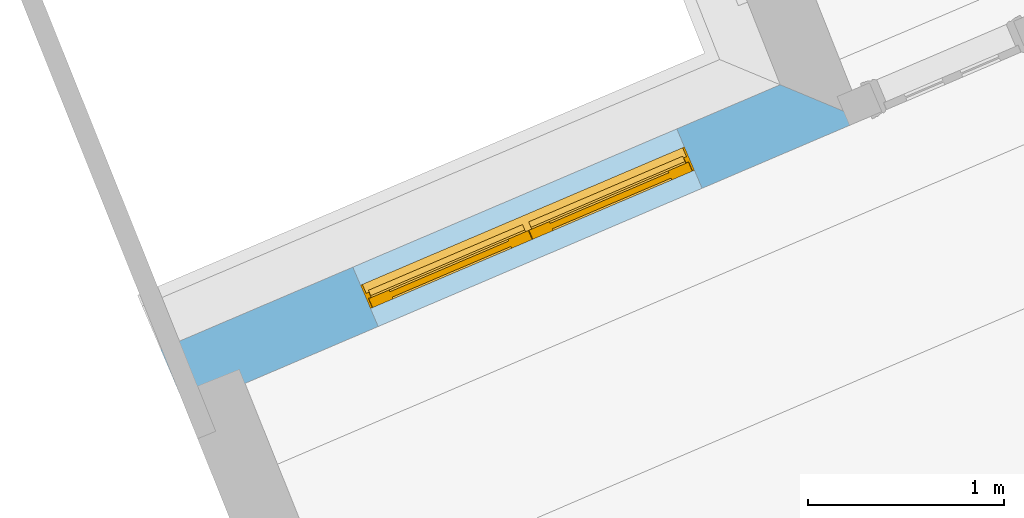
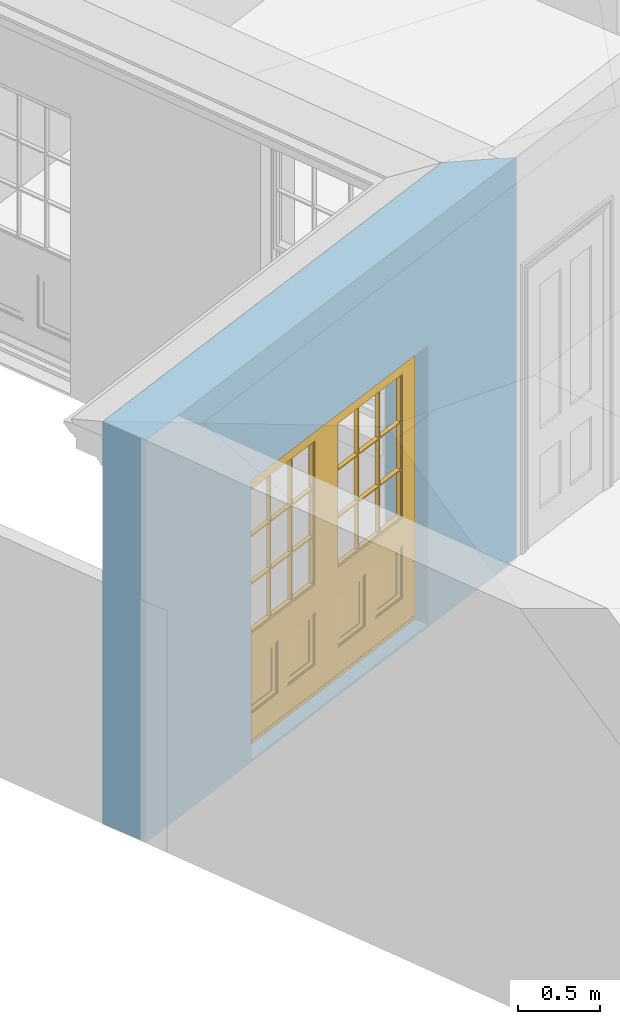
# One storey, part 2 of 19: 1 door, 1 opening, plus 1 element that does not belong to this part.
"""IFC2X3 building model written with IfcOpenShell, lengths in metres."""

from ifc_helpers import new_model, si_unit, frame, origin, place, context, subcontext, project, spatial, polyline, outline, extrude, faceted_brep, material, layer, layer_set, layer_usage, element, fill, save


model = new_model("IFC2X3")

# Units and contexts
model_context = context("Model", 3, world=origin())
body_context = subcontext(model_context, "Body", "Model", "MODEL_VIEW")
ifc_project = project(units=[si_unit("PLANEANGLEUNIT", "RADIAN"), si_unit("MASSUNIT", "GRAM", prefix="KILO"), si_unit("FORCEUNIT", "NEWTON", prefix="KILO"), si_unit("LENGTHUNIT", "METRE")], contexts=[model_context])

# Site, building, storey
site_placement = place(None, origin())
site = spatial("IfcSite", under=ifc_project, at=site_placement, CompositionType="ELEMENT")
building_placement = place(None, origin())
building = spatial("IfcBuilding", under=site, at=building_placement, Name="Building plot-0", CompositionType="ELEMENT")
storey_placement = place(None, origin())
storey = spatial("IfcBuildingStorey", under=building, at=storey_placement, Name="Floor 0", CompositionType="ELEMENT", Elevation=0.0)

# Wall, opening, door
ifc_material = material(Name="Masonry")
ifc_layer = layer(ifc_material, 0.33, ventilated=False)
ifc_layer_set = layer_set([ifc_layer], Name="My Wall")
ifc_layer_usage = layer_usage(ifc_layer_set, "AXIS2", "NEGATIVE", 0.08)
wall_placement = place(storey_placement, origin())
wall = element("IfcWallStandardCase", 1, at=wall_placement, inside=storey, material=ifc_layer_usage, Name="exterior", context=body_context, shape_type="SweptSolid", body=[
    extrude(outline(polyline([(17.784510830655, 26.584810219007), (17.3592391354437, 26.7621166784652), (14.1922339119998, 25.4105779251313), (14.3217616381447, 25.1070609269916), (17.784510830655, 26.584810219007)])), origin(), (0.0, 0.0, 1.0), 3.0),
])
opening_placement = place(storey_placement, frame((0.0, 0.0, 0.02)))
opening = element("IfcOpeningElement", 2, at=opening_placement, cuts=wall, Name="Opening", ObjectType="Opening", context=body_context, shape_type="SweptSolid", body=[
    extrude(outline(polyline([(16.8305029456204, 26.5364752915971), (15.17495568304, 25.8299604217163), (15.3044834091848, 25.5264434235766), (16.9600306717652, 26.2329582934574), (16.8305029456204, 26.5364752915971)])), origin(), (0.0, 0.0, 1.0), 2.08),
])
door_placement = place(storey_placement, frame((16.9286300108816, 26.3065381717943, 0.02), z_axis=(0.0, 0.0, 1.0), x_axis=(-1.65554726258036, -0.706514869880795, 0.0)))
door = element("IfcDoor", 3, at=door_placement, inside=storey, Name="living outside door", OverallHeight=2.08, OverallWidth=1.8, context=body_context, shape_type="Brep", held_by="IfcProductRepresentation", body=[
    faceted_brep([(0.545, -0.055, 0.265), (0.745, -0.055, 0.265), (0.745, -0.05, 0.265), (0.545, -0.05, 0.265), (0.745, -0.05, 0.58), (0.545, -0.05, 0.58), (0.545, -0.055, 0.58), (0.515, -0.06, 0.235), (0.775, -0.06, 0.235), (0.745, -0.055, 0.58), (0.515, -0.06, 0.61), (0.515, -0.065, 0.235), (0.775, -0.065, 0.235), (0.775, -0.06, 0.61), (0.515, -0.065, 0.61), (0.785, -0.065, 0.225), (0.505, -0.065, 0.225), (0.775, -0.065, 0.61), (0.505, -0.065, 0.62), (0.785, -0.065, 0.62), (0.505, -0.07, 0.225), (0.785, -0.07, 0.225), (0.505, -0.07, 0.62), (0.785, -0.07, 0.62), (0.883, -0.07, 0.075), (0.898, -0.07, 0.075), (0.405, -0.07, 0.62), (0.405, -0.07, 0.225), (0.027, -0.07, 0.075), (0.785, -0.07, 0.82), (0.125, -0.07, 0.82), (0.405, -0.065, 0.62), (0.405, -0.065, 0.225), (0.898, -0.07, 2.068), (0.027, -0.08, 0.075), (0.883, -0.08, 0.075), (0.125, -0.07, 0.225), (0.012, -0.07, 0.075), (0.785, -0.06, 0.82), (0.125, -0.06, 0.82), (0.125, -0.07, 0.62), (0.125, -0.065, 0.62), (0.395, -0.065, 0.61), (0.395, -0.065, 0.235), (0.125, -0.065, 0.225), (0.785, -0.07, 1.895), (0.027, -0.11, 0.045), (0.883, -0.11, 0.045), (0.558333, -0.06, 0.83), (0.351667, -0.06, 0.83), (0.125, -0.07, 1.895), (0.125, -0.06, 1.895), (0.785, -0.06, 1.895), (0.012, -0.07, 2.068), (0.135, -0.065, 0.61), (0.395, -0.06, 0.61), (0.395, -0.06, 0.235), (0.135, -0.065, 0.235), (0.027, -0.11, 0.027), (0.883, -0.11, 0.027), (0.568333, -0.06, 0.83), (0.558333, -0.03, 0.83), (0.351667, -0.03, 0.83), (0.341667, -0.06, 0.83), (0.135, -0.06, 1.185), (0.135, -0.06, 1.53), (0.775, -0.06, 1.53), (0.775, -0.06, 1.185), (0.135, -0.06, 0.61), (0.365, -0.055, 0.58), (0.365, -0.055, 0.265), (0.135, -0.06, 0.235), (0.568333, -0.06, 1.175), (0.558333, -0.06, 1.175), (0.775, -0.06, 0.83), (0.558333, -0.03, 1.175), (0.785, -0.03, 0.82), (0.125, -0.03, 0.82), (0.351667, -0.03, 1.175), (0.351667, -0.06, 1.175), (0.341667, -0.06, 1.175), (0.135, -0.06, 0.83), (0.135, -0.06, 1.175), (0.135, -0.03, 1.185), (0.135, -0.03, 1.53), (0.135, -0.06, 1.54), (0.351667, -0.06, 1.885), (0.558333, -0.06, 1.885), (0.775, -0.03, 1.53), (0.775, -0.03, 1.185), (0.775, -0.06, 1.175), (0.775, -0.06, 1.54), (0.165, -0.055, 0.58), (0.365, -0.05, 0.58), (0.365, -0.05, 0.265), (0.165, -0.055, 0.265), (0.568333, -0.03, 0.83), (0.568333, -0.03, 1.175), (0.568333, -0.06, 1.185), (0.558333, -0.06, 1.185), (0.775, -0.03, 0.83), (0.785, -0.02, 0.82), (0.125, -0.02, 0.82), (0.341667, -0.03, 0.83), (0.341667, -0.03, 1.175), (0.351667, -0.06, 1.185), (0.341667, -0.06, 1.185), (0.135, -0.03, 0.83), (0.341667, -0.03, 1.185), (0.125, -0.03, 1.895), (0.341667, -0.03, 1.53), (0.341667, -0.06, 1.53), (0.135, -0.06, 1.885), (0.341667, -0.06, 1.54), (0.341667, -0.06, 1.885), (0.558333, -0.03, 1.885), (0.351667, -0.03, 1.885), (0.568333, -0.06, 1.885), (0.785, -0.03, 1.895), (0.568333, -0.03, 1.185), (0.568333, -0.06, 1.53), (0.568333, -0.03, 1.53), (0.568333, -0.06, 1.54), (0.775, -0.06, 1.885), (0.165, -0.05, 0.58), (0.165, -0.05, 0.265), (0.775, -0.03, 1.175), (0.558333, -0.06, 1.53), (0.351667, -0.03, 1.185), (0.558333, -0.03, 1.185), (0.505, -0.02, 0.62), (0.405, -0.02, 0.62), (0.125, -0.02, 1.895), (0.785, -0.02, 1.895), (0.351667, -0.06, 1.53), (0.135, -0.03, 1.175), (0.135, -0.03, 1.54), (0.341667, -0.03, 1.54), (0.135, -0.03, 1.885), (0.351667, -0.06, 1.54), (0.558333, -0.03, 1.54), (0.558333, -0.06, 1.54), (0.351667, -0.03, 1.54), (0.775, -0.03, 1.54), (0.568333, -0.03, 1.54), (0.775, -0.03, 1.885), (0.558333, -0.03, 1.53), (0.405, -0.02, 0.225), (0.505, -0.02, 0.225), (0.125, -0.02, 0.62), (0.785, -0.02, 0.62), (0.012, -0.02, 2.068), (0.898, -0.02, 2.068), (0.351667, -0.03, 1.53), (0.341667, -0.03, 1.885), (0.568333, -0.03, 1.885), (0.405, -0.025, 0.225), (0.405, -0.025, 0.62), (0.505, -0.025, 0.62), (0.505, -0.025, 0.225), (0.898, -0.02, 0.027), (0.012, -0.02, 0.027), (0.125, -0.025, 0.62), (0.785, -0.025, 0.62), (0.395, -0.025, 0.235), (0.395, -0.025, 0.61), (0.125, -0.02, 0.225), (0.125, -0.025, 0.225), (0.515, -0.025, 0.61), (0.515, -0.025, 0.235), (0.785, -0.02, 0.225), (0.785, -0.025, 0.225), (0.135, -0.025, 0.61), (0.775, -0.025, 0.61), (0.135, -0.025, 0.235), (0.395, -0.03, 0.235), (0.395, -0.03, 0.61), (0.515, -0.03, 0.61), (0.515, -0.03, 0.235), (0.775, -0.025, 0.235), (0.135, -0.03, 0.61), (0.775, -0.03, 0.61), (0.135, -0.03, 0.235), (0.365, -0.035, 0.265), (0.365, -0.035, 0.58), (0.545, -0.035, 0.58), (0.545, -0.035, 0.265), (0.775, -0.03, 0.235), (0.165, -0.035, 0.58), (0.745, -0.035, 0.58), (0.165, -0.035, 0.265), (0.365, -0.04, 0.58), (0.365, -0.04, 0.265), (0.545, -0.04, 0.58), (0.545, -0.04, 0.265), (0.745, -0.035, 0.265), (0.165, -0.04, 0.58), (0.745, -0.04, 0.58), (0.165, -0.04, 0.265), (0.745, -0.04, 0.265), (1.775, -0.072, 0.025), (0.025, -0.072, 0.025), (0.025, -0.1, 0.025), (1.775, -0.1, 0.025), (1.79, -0.02, 0.025), (0.01, -0.02, 0.025), (1.79, -0.072, 0.025), (1.8, -0.02, 0.0), (0.0, -0.02, 0.0), (0.01, -0.072, 0.025), (1.79, -0.072, 2.07), (1.79, -0.02, 2.07), (1.775, -0.072, 2.055), (1.8, -0.02, 2.08), (0.01, -0.02, 2.07), (0.0, -0.02, 2.08), (0.01, -0.072, 2.07), (0.025, -0.072, 2.055), (0.0, -0.15, 2.08), (1.8, -0.15, 2.08), (0.01, -0.15, 2.07), (1.79, -0.15, 2.07), (0.01, -0.1, 2.07), (1.79, -0.1, 2.07), (0.0, -0.15, 0.0), (1.8, -0.15, 0.0), (0.01, -0.15, 0.025), (1.79, -0.15, 0.025), (0.01, -0.1, 0.025), (0.025, -0.1, 2.055), (1.79, -0.1, 0.025), (1.775, -0.1, 2.055), (0.898, -0.07, 0.027), (0.012, -0.07, 0.027), (0.883, -0.07, 0.027), (0.027, -0.07, 0.027), (1.435, -0.055, 0.265), (1.635, -0.055, 0.265), (1.635, -0.05, 0.265), (1.435, -0.05, 0.265), (1.635, -0.05, 0.58), (1.435, -0.05, 0.58), (1.435, -0.055, 0.58), (1.405, -0.06, 0.235), (1.665, -0.06, 0.235), (1.635, -0.055, 0.58), (1.405, -0.06, 0.61), (1.405, -0.065, 0.235), (1.665, -0.065, 0.235), (1.665, -0.06, 0.61), (1.405, -0.065, 0.61), (1.675, -0.065, 0.225), (1.395, -0.065, 0.225), (1.665, -0.065, 0.61), (1.395, -0.065, 0.62), (1.675, -0.065, 0.62), (1.395, -0.07, 0.225), (1.675, -0.07, 0.225), (1.395, -0.07, 0.62), (1.675, -0.07, 0.62), (1.773, -0.07, 0.075), (1.788, -0.07, 0.075), (1.295, -0.07, 0.62), (1.295, -0.07, 0.225), (0.917, -0.07, 0.075), (1.675, -0.07, 0.82), (1.015, -0.07, 0.82), (1.295, -0.065, 0.62), (1.295, -0.065, 0.225), (1.788, -0.07, 2.068), (0.917, -0.08, 0.075), (1.773, -0.08, 0.075), (1.015, -0.07, 0.225), (0.902, -0.07, 0.075), (1.675, -0.06, 0.82), (1.015, -0.06, 0.82), (1.015, -0.07, 0.62), (1.015, -0.065, 0.62), (1.285, -0.065, 0.61), (1.285, -0.065, 0.235), (1.015, -0.065, 0.225), (1.675, -0.07, 1.895), (0.917, -0.11, 0.045), (1.773, -0.11, 0.045), (1.448333, -0.06, 0.83), (1.241667, -0.06, 0.83), (1.015, -0.07, 1.895), (1.015, -0.06, 1.895), (1.675, -0.06, 1.895), (0.902, -0.07, 2.068), (1.025, -0.065, 0.61), (1.285, -0.06, 0.61), (1.285, -0.06, 0.235), (1.025, -0.065, 0.235), (0.917, -0.11, 0.027), (1.773, -0.11, 0.027), (1.458333, -0.06, 0.83), (1.448333, -0.03, 0.83), (1.241667, -0.03, 0.83), (1.231667, -0.06, 0.83), (1.025, -0.06, 1.185), (1.025, -0.06, 1.53), (1.665, -0.06, 1.53), (1.665, -0.06, 1.185), (1.025, -0.06, 0.61), (1.255, -0.055, 0.58), (1.255, -0.055, 0.265), (1.025, -0.06, 0.235), (1.458333, -0.06, 1.175), (1.448333, -0.06, 1.175), (1.665, -0.06, 0.83), (1.448333, -0.03, 1.175), (1.675, -0.03, 0.82), (1.015, -0.03, 0.82), (1.241667, -0.03, 1.175), (1.241667, -0.06, 1.175), (1.231667, -0.06, 1.175), (1.025, -0.06, 0.83), (1.025, -0.06, 1.175), (1.025, -0.03, 1.185), (1.025, -0.03, 1.53), (1.025, -0.06, 1.54), (1.241667, -0.06, 1.885), (1.448333, -0.06, 1.885), (1.665, -0.03, 1.53), (1.665, -0.03, 1.185), (1.665, -0.06, 1.175), (1.665, -0.06, 1.54), (1.055, -0.055, 0.58), (1.255, -0.05, 0.58), (1.255, -0.05, 0.265), (1.055, -0.055, 0.265), (1.458333, -0.03, 0.83), (1.458333, -0.03, 1.175), (1.458333, -0.06, 1.185), (1.448333, -0.06, 1.185), (1.665, -0.03, 0.83), (1.675, -0.02, 0.82), (1.015, -0.02, 0.82), (1.231667, -0.03, 0.83), (1.231667, -0.03, 1.175), (1.241667, -0.06, 1.185), (1.231667, -0.06, 1.185), (1.025, -0.03, 0.83), (1.231667, -0.03, 1.185), (1.015, -0.03, 1.895), (1.231667, -0.03, 1.53), (1.231667, -0.06, 1.53), (1.025, -0.06, 1.885), (1.231667, -0.06, 1.54), (1.231667, -0.06, 1.885), (1.448333, -0.03, 1.885), (1.241667, -0.03, 1.885), (1.458333, -0.06, 1.885), (1.675, -0.03, 1.895), (1.458333, -0.03, 1.185), (1.458333, -0.06, 1.53), (1.458333, -0.03, 1.53), (1.458333, -0.06, 1.54), (1.665, -0.06, 1.885), (1.055, -0.05, 0.58), (1.055, -0.05, 0.265), (1.665, -0.03, 1.175), (1.448333, -0.06, 1.53), (1.241667, -0.03, 1.185), (1.448333, -0.03, 1.185), (1.395, -0.02, 0.62), (1.295, -0.02, 0.62), (1.015, -0.02, 1.895), (1.675, -0.02, 1.895), (1.241667, -0.06, 1.53), (1.025, -0.03, 1.175), (1.025, -0.03, 1.54), (1.231667, -0.03, 1.54), (1.025, -0.03, 1.885), (1.241667, -0.06, 1.54), (1.448333, -0.03, 1.54), (1.448333, -0.06, 1.54), (1.241667, -0.03, 1.54), (1.665, -0.03, 1.54), (1.458333, -0.03, 1.54), (1.665, -0.03, 1.885), (1.448333, -0.03, 1.53), (1.295, -0.02, 0.225), (1.395, -0.02, 0.225), (1.015, -0.02, 0.62), (1.675, -0.02, 0.62), (0.902, -0.02, 2.068), (1.788, -0.02, 2.068), (1.241667, -0.03, 1.53), (1.231667, -0.03, 1.885), (1.458333, -0.03, 1.885), (1.295, -0.025, 0.225), (1.295, -0.025, 0.62), (1.395, -0.025, 0.62), (1.395, -0.025, 0.225), (1.788, -0.02, 0.027), (0.902, -0.02, 0.027), (1.015, -0.025, 0.62), (1.675, -0.025, 0.62), (1.285, -0.025, 0.235), (1.285, -0.025, 0.61), (1.015, -0.02, 0.225), (1.015, -0.025, 0.225), (1.405, -0.025, 0.61), (1.405, -0.025, 0.235), (1.675, -0.02, 0.225), (1.675, -0.025, 0.225), (1.025, -0.025, 0.61), (1.665, -0.025, 0.61), (1.025, -0.025, 0.235), (1.285, -0.03, 0.235), (1.285, -0.03, 0.61), (1.405, -0.03, 0.61), (1.405, -0.03, 0.235), (1.665, -0.025, 0.235), (1.025, -0.03, 0.61), (1.665, -0.03, 0.61), (1.025, -0.03, 0.235), (1.255, -0.035, 0.265), (1.255, -0.035, 0.58), (1.435, -0.035, 0.58), (1.435, -0.035, 0.265), (1.665, -0.03, 0.235), (1.055, -0.035, 0.58), (1.635, -0.035, 0.58), (1.055, -0.035, 0.265), (1.255, -0.04, 0.58), (1.255, -0.04, 0.265), (1.435, -0.04, 0.58), (1.435, -0.04, 0.265), (1.635, -0.035, 0.265), (1.055, -0.04, 0.58), (1.635, -0.04, 0.58), (1.055, -0.04, 0.265), (1.635, -0.04, 0.265), (1.788, -0.07, 0.027), (0.902, -0.07, 0.027), (1.773, -0.07, 0.027), (0.917, -0.07, 0.027)], [[[0, 1, 2, 3]], [[2, 4, 5, 3]], [[0, 3, 5, 6]], [[1, 0, 7, 8]], [[9, 4, 2, 1]], [[9, 6, 5, 4]], [[0, 6, 10, 7]], [[8, 7, 11, 12]], [[8, 13, 9, 1]], [[13, 10, 6, 9]], [[7, 10, 14, 11]], [[15, 12, 11, 16]], [[12, 17, 13, 8]], [[17, 14, 10, 13]], [[18, 16, 11, 14]], [[15, 19, 17, 12]], [[15, 16, 20, 21]], [[14, 17, 19, 18]], [[16, 18, 22, 20]], [[21, 23, 19, 15]], [[24, 25, 21, 20]], [[23, 22, 18, 19]], [[20, 22, 26, 27]], [[23, 21, 25]], [[28, 24, 20, 27]], [[22, 23, 29]], [[29, 30, 26, 22]], [[27, 26, 31, 32]], [[23, 25, 33, 29]], [[34, 35, 24, 28]], [[28, 27, 36, 37]], [[38, 39, 30, 29]], [[26, 30, 40]], [[26, 40, 41, 31]], [[42, 43, 32, 31]], [[32, 44, 36, 27]], [[33, 45, 29]], [[46, 47, 35, 34]], [[36, 40, 37]], [[39, 38, 48, 49]], [[50, 30, 39, 51]], [[29, 45, 52, 38]], [[53, 37, 40, 30]], [[44, 41, 40, 36]], [[31, 41, 54, 42]], [[43, 42, 55, 56]], [[57, 44, 32, 43]], [[50, 45, 33, 53]], [[47, 46, 58, 59]], [[60, 48, 38]], [[49, 48, 61, 62]], [[49, 63, 39]], [[50, 53, 30]], [[51, 39, 64, 65]], [[45, 50, 51, 52]], [[66, 67, 38, 52]], [[57, 54, 41, 44]], [[42, 54, 68, 55]], [[56, 55, 69, 70]], [[56, 71, 57, 43]], [[60, 72, 73, 48]], [[60, 38, 74]], [[48, 73, 75, 61]], [[76, 77, 62, 61]], [[62, 78, 79, 49]], [[49, 79, 80, 63]], [[63, 81, 39]], [[82, 64, 39]], [[65, 64, 83, 84]], [[85, 51, 65]], [[52, 51, 86, 87]], [[88, 89, 67, 66]], [[90, 38, 67]], [[91, 66, 52]], [[71, 68, 54, 57]], [[55, 68, 92, 69]], [[69, 93, 94, 70]], [[70, 95, 71, 56]], [[96, 97, 72, 60]], [[73, 72, 98, 99]], [[74, 38, 90]], [[100, 96, 60, 74]], [[75, 73, 79, 78]], [[61, 75, 97, 96]], [[101, 102, 77, 76]], [[77, 103, 62]], [[96, 76, 61]], [[103, 104, 78, 62]], [[80, 79, 105, 106]], [[63, 80, 104, 103]], [[81, 63, 103, 107]], [[81, 82, 39]], [[106, 64, 82, 80]], [[106, 108, 83, 64]], [[84, 83, 77, 109]], [[110, 111, 65, 84]], [[112, 51, 85]], [[113, 85, 65, 111]], [[114, 86, 51]], [[115, 87, 86, 116]], [[117, 52, 87]], [[118, 76, 89, 88]], [[119, 98, 67, 89]], [[120, 121, 88, 66]], [[67, 98, 72, 90]], [[91, 122, 120, 66]], [[91, 52, 123]], [[95, 92, 68, 71]], [[69, 92, 124, 93]], [[94, 93, 124, 125]], [[94, 125, 95, 70]], [[72, 97, 126, 90]], [[127, 99, 98, 120]], [[99, 105, 79, 73]], [[74, 90, 126, 100]], [[96, 100, 76]], [[128, 129, 75, 78]], [[97, 75, 129, 119]], [[130, 131, 102, 101]], [[109, 77, 102, 132]], [[133, 101, 76, 118]], [[77, 107, 103]], [[78, 104, 108, 128]], [[111, 106, 105, 134]], [[104, 80, 82, 135]], [[107, 135, 82, 81]], [[110, 108, 106, 111]], [[104, 135, 83, 108]], [[83, 135, 77]], [[136, 84, 109]], [[110, 84, 136, 137]], [[114, 51, 112]], [[85, 136, 138, 112]], [[113, 137, 136, 85]], [[111, 134, 139, 113]], [[86, 114, 113, 139]], [[140, 141, 87, 115]], [[139, 142, 116, 86]], [[109, 118, 115, 116]], [[117, 123, 52]], [[117, 87, 141, 122]], [[126, 89, 76]], [[143, 118, 88]], [[120, 98, 119, 121]], [[119, 89, 126, 97]], [[144, 143, 88, 121]], [[144, 122, 91, 143]], [[127, 120, 122, 141]], [[143, 91, 123, 145]], [[124, 92, 95, 125]], [[146, 129, 99, 127]], [[99, 129, 128, 105]], [[100, 126, 76]], [[121, 119, 129, 146]], [[147, 131, 130, 148]], [[131, 149, 102]], [[130, 101, 150]], [[102, 151, 132]], [[118, 109, 132, 133]], [[101, 133, 152]], [[107, 77, 135]], [[153, 128, 108, 110]], [[134, 105, 128, 153]], [[109, 138, 136]], [[153, 110, 137, 142]], [[154, 114, 112, 138]], [[137, 113, 114, 154]], [[141, 139, 134, 127]], [[141, 140, 142, 139]], [[144, 140, 115, 155]], [[142, 137, 154, 116]], [[155, 115, 118]], [[116, 154, 109]], [[117, 155, 145, 123]], [[122, 144, 155, 117]], [[143, 145, 118]], [[121, 146, 140, 144]], [[146, 127, 134, 153]], [[156, 157, 131, 147]], [[148, 130, 158, 159]], [[148, 160, 161, 147]], [[157, 162, 149, 131]], [[161, 151, 102, 149]], [[101, 152, 160, 150]], [[163, 158, 130, 150]], [[151, 152, 133, 132]], [[154, 138, 109]], [[142, 140, 146, 153]], [[145, 155, 118]], [[157, 156, 164, 165]], [[147, 166, 167, 156]], [[168, 169, 159, 158]], [[170, 148, 159, 171]], [[148, 170, 160]], [[166, 147, 161]], [[172, 162, 157, 165]], [[166, 149, 162, 167]], [[166, 161, 149]], [[150, 160, 170]], [[163, 173, 168, 158]], [[171, 163, 150, 170]], [[174, 164, 156, 167]], [[175, 176, 165, 164]], [[169, 168, 177, 178]], [[171, 159, 169, 179]], [[167, 162, 172, 174]], [[176, 180, 172, 165]], [[179, 173, 163, 171]], [[181, 177, 168, 173]], [[164, 174, 182, 175]], [[183, 184, 176, 175]], [[178, 177, 185, 186]], [[179, 169, 178, 187]], [[174, 172, 180, 182]], [[184, 188, 180, 176]], [[187, 181, 173, 179]], [[189, 185, 177, 181]], [[175, 182, 190, 183]], [[191, 184, 183, 192]], [[185, 193, 194, 186]], [[187, 178, 186, 195]], [[182, 180, 188, 190]], [[191, 196, 188, 184]], [[195, 189, 181, 187]], [[197, 193, 185, 189]], [[183, 190, 198, 192]], [[198, 196, 191, 192]], [[194, 193, 197, 199]], [[195, 186, 194, 199]], [[188, 196, 198, 190]], [[197, 189, 195, 199]], [[200, 201, 202, 203]], [[201, 200, 204, 205]], [[206, 204, 200]], [[204, 207, 208, 205]], [[209, 201, 205]], [[210, 211, 204, 206]], [[206, 200, 212, 210]], [[211, 213, 207, 204]], [[214, 205, 208, 215]], [[216, 217, 201, 209]], [[205, 214, 216, 209]], [[216, 214, 211, 210]], [[210, 212, 217, 216]], [[214, 215, 213, 211]], [[218, 219, 213, 215]], [[219, 218, 220, 221]], [[221, 220, 222, 223]], [[215, 208, 224, 218]], [[225, 224, 208, 207]], [[224, 226, 220, 218]], [[224, 225, 227, 226]], [[219, 225, 207, 213]], [[228, 222, 220, 226]], [[219, 221, 227, 225]], [[226, 227, 203, 202]], [[202, 229, 222, 228]], [[228, 226, 202]], [[227, 221, 223, 230]], [[230, 203, 227]], [[217, 229, 202, 201]], [[231, 223, 222, 229]], [[230, 223, 231, 203]], [[231, 229, 217, 212]], [[212, 200, 203, 231]], [[33, 152, 151, 53]], [[25, 160, 152, 33]], [[161, 37, 53, 151]], [[232, 160, 25]], [[161, 233, 37]], [[160, 232, 234]], [[24, 234, 232, 25]], [[233, 161, 235]], [[37, 233, 235, 28]], [[161, 160, 234, 235]], [[35, 47, 234, 24]], [[28, 235, 46, 34]], [[58, 235, 234, 59]], [[59, 234, 47]], [[58, 46, 235]], [[236, 237, 238, 239]], [[238, 240, 241, 239]], [[236, 239, 241, 242]], [[237, 236, 243, 244]], [[245, 240, 238, 237]], [[245, 242, 241, 240]], [[236, 242, 246, 243]], [[244, 243, 247, 248]], [[244, 249, 245, 237]], [[249, 246, 242, 245]], [[243, 246, 250, 247]], [[251, 248, 247, 252]], [[248, 253, 249, 244]], [[253, 250, 246, 249]], [[254, 252, 247, 250]], [[251, 255, 253, 248]], [[251, 252, 256, 257]], [[250, 253, 255, 254]], [[252, 254, 258, 256]], [[257, 259, 255, 251]], [[260, 261, 257, 256]], [[259, 258, 254, 255]], [[256, 258, 262, 263]], [[259, 257, 261]], [[264, 260, 256, 263]], [[258, 259, 265]], [[265, 266, 262, 258]], [[263, 262, 267, 268]], [[259, 261, 269, 265]], [[270, 271, 260, 264]], [[264, 263, 272, 273]], [[274, 275, 266, 265]], [[262, 266, 276]], [[262, 276, 277, 267]], [[278, 279, 268, 267]], [[268, 280, 272, 263]], [[269, 281, 265]], [[282, 283, 271, 270]], [[272, 276, 273]], [[275, 274, 284, 285]], [[286, 266, 275, 287]], [[265, 281, 288, 274]], [[289, 273, 276, 266]], [[280, 277, 276, 272]], [[267, 277, 290, 278]], [[279, 278, 291, 292]], [[293, 280, 268, 279]], [[286, 281, 269, 289]], [[283, 282, 294, 295]], [[296, 284, 274]], [[285, 284, 297, 298]], [[285, 299, 275]], [[286, 289, 266]], [[287, 275, 300, 301]], [[281, 286, 287, 288]], [[302, 303, 274, 288]], [[293, 290, 277, 280]], [[278, 290, 304, 291]], [[292, 291, 305, 306]], [[292, 307, 293, 279]], [[296, 308, 309, 284]], [[296, 274, 310]], [[284, 309, 311, 297]], [[312, 313, 298, 297]], [[298, 314, 315, 285]], [[285, 315, 316, 299]], [[299, 317, 275]], [[318, 300, 275]], [[301, 300, 319, 320]], [[321, 287, 301]], [[288, 287, 322, 323]], [[324, 325, 303, 302]], [[326, 274, 303]], [[327, 302, 288]], [[307, 304, 290, 293]], [[291, 304, 328, 305]], [[305, 329, 330, 306]], [[306, 331, 307, 292]], [[332, 333, 308, 296]], [[309, 308, 334, 335]], [[310, 274, 326]], [[336, 332, 296, 310]], [[311, 309, 315, 314]], [[297, 311, 333, 332]], [[337, 338, 313, 312]], [[313, 339, 298]], [[332, 312, 297]], [[339, 340, 314, 298]], [[316, 315, 341, 342]], [[299, 316, 340, 339]], [[317, 299, 339, 343]], [[317, 318, 275]], [[342, 300, 318, 316]], [[342, 344, 319, 300]], [[320, 319, 313, 345]], [[346, 347, 301, 320]], [[348, 287, 321]], [[349, 321, 301, 347]], [[350, 322, 287]], [[351, 323, 322, 352]], [[353, 288, 323]], [[354, 312, 325, 324]], [[355, 334, 303, 325]], [[356, 357, 324, 302]], [[303, 334, 308, 326]], [[327, 358, 356, 302]], [[327, 288, 359]], [[331, 328, 304, 307]], [[305, 328, 360, 329]], [[330, 329, 360, 361]], [[330, 361, 331, 306]], [[308, 333, 362, 326]], [[363, 335, 334, 356]], [[335, 341, 315, 309]], [[310, 326, 362, 336]], [[332, 336, 312]], [[364, 365, 311, 314]], [[333, 311, 365, 355]], [[366, 367, 338, 337]], [[345, 313, 338, 368]], [[369, 337, 312, 354]], [[313, 343, 339]], [[314, 340, 344, 364]], [[347, 342, 341, 370]], [[340, 316, 318, 371]], [[343, 371, 318, 317]], [[346, 344, 342, 347]], [[340, 371, 319, 344]], [[319, 371, 313]], [[372, 320, 345]], [[346, 320, 372, 373]], [[350, 287, 348]], [[321, 372, 374, 348]], [[349, 373, 372, 321]], [[347, 370, 375, 349]], [[322, 350, 349, 375]], [[376, 377, 323, 351]], [[375, 378, 352, 322]], [[345, 354, 351, 352]], [[353, 359, 288]], [[353, 323, 377, 358]], [[362, 325, 312]], [[379, 354, 324]], [[356, 334, 355, 357]], [[355, 325, 362, 333]], [[380, 379, 324, 357]], [[380, 358, 327, 379]], [[363, 356, 358, 377]], [[379, 327, 359, 381]], [[360, 328, 331, 361]], [[382, 365, 335, 363]], [[335, 365, 364, 341]], [[336, 362, 312]], [[357, 355, 365, 382]], [[383, 367, 366, 384]], [[367, 385, 338]], [[366, 337, 386]], [[338, 387, 368]], [[354, 345, 368, 369]], [[337, 369, 388]], [[343, 313, 371]], [[389, 364, 344, 346]], [[370, 341, 364, 389]], [[345, 374, 372]], [[389, 346, 373, 378]], [[390, 350, 348, 374]], [[373, 349, 350, 390]], [[377, 375, 370, 363]], [[377, 376, 378, 375]], [[380, 376, 351, 391]], [[378, 373, 390, 352]], [[391, 351, 354]], [[352, 390, 345]], [[353, 391, 381, 359]], [[358, 380, 391, 353]], [[379, 381, 354]], [[357, 382, 376, 380]], [[382, 363, 370, 389]], [[392, 393, 367, 383]], [[384, 366, 394, 395]], [[384, 396, 397, 383]], [[393, 398, 385, 367]], [[397, 387, 338, 385]], [[337, 388, 396, 386]], [[399, 394, 366, 386]], [[387, 388, 369, 368]], [[390, 374, 345]], [[378, 376, 382, 389]], [[381, 391, 354]], [[393, 392, 400, 401]], [[383, 402, 403, 392]], [[404, 405, 395, 394]], [[406, 384, 395, 407]], [[384, 406, 396]], [[402, 383, 397]], [[408, 398, 393, 401]], [[402, 385, 398, 403]], [[402, 397, 385]], [[386, 396, 406]], [[399, 409, 404, 394]], [[407, 399, 386, 406]], [[410, 400, 392, 403]], [[411, 412, 401, 400]], [[405, 404, 413, 414]], [[407, 395, 405, 415]], [[403, 398, 408, 410]], [[412, 416, 408, 401]], [[415, 409, 399, 407]], [[417, 413, 404, 409]], [[400, 410, 418, 411]], [[419, 420, 412, 411]], [[414, 413, 421, 422]], [[415, 405, 414, 423]], [[410, 408, 416, 418]], [[420, 424, 416, 412]], [[423, 417, 409, 415]], [[425, 421, 413, 417]], [[411, 418, 426, 419]], [[427, 420, 419, 428]], [[421, 429, 430, 422]], [[423, 414, 422, 431]], [[418, 416, 424, 426]], [[427, 432, 424, 420]], [[431, 425, 417, 423]], [[433, 429, 421, 425]], [[419, 426, 434, 428]], [[434, 432, 427, 428]], [[430, 429, 433, 435]], [[431, 422, 430, 435]], [[424, 432, 434, 426]], [[433, 425, 431, 435]], [[269, 388, 387, 289]], [[261, 396, 388, 269]], [[397, 273, 289, 387]], [[436, 396, 261]], [[397, 437, 273]], [[396, 436, 438]], [[260, 438, 436, 261]], [[437, 397, 439]], [[273, 437, 439, 264]], [[397, 396, 438, 439]], [[271, 283, 438, 260]], [[264, 439, 282, 270]], [[294, 439, 438, 295]], [[295, 438, 283]], [[294, 282, 439]]]),
])
fill(opening, door)

save(model, "model.ifc")
